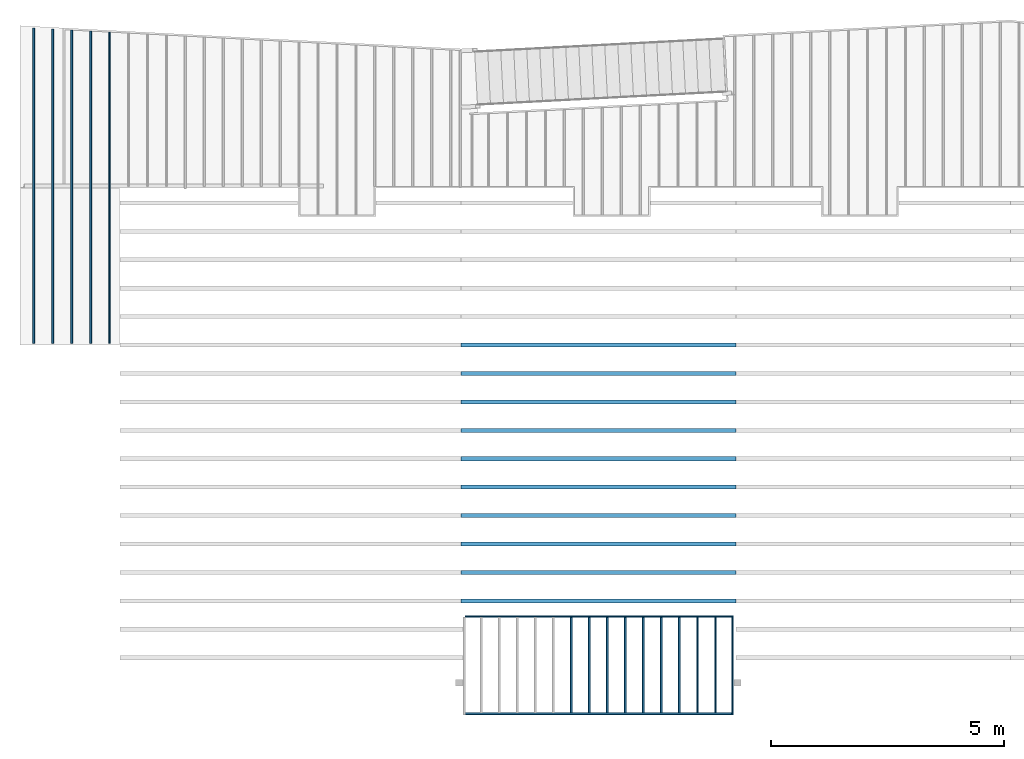
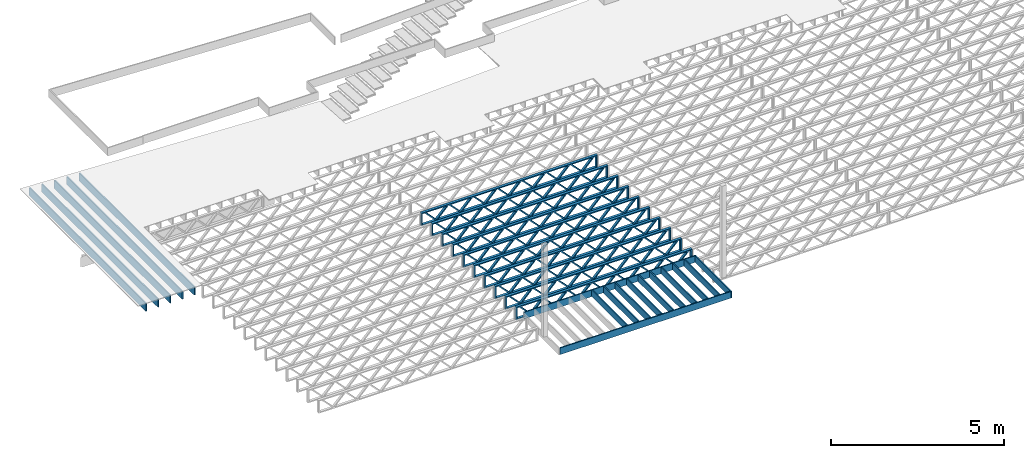
# One storey, part 2 of 23: 27 beams, 3 elements without a shape of their own.
"""IFC4 building model written with IfcOpenShell, lengths in feet."""

from ifc_helpers import new_model, entity, si_unit, converted_unit, derived_unit, direction, frame, frame_2d, origin, origin_2d_with_axis, place, context, subcontext, project, spatial, rectangle, extrude, source, transform, mapped, material, material_profile, profile_set, profile_usage, type_object, type_shapes, element, aggregate, save


model = new_model("IFC4")

# Units and contexts
model_context_1 = context("Model", 3, precision=0.0001, world=origin(), true_north=direction((6.12303176911189e-17, 1.0)))
model_context_2 = context("Model", 3, precision=0.0001, world=origin(), true_north=direction((6.12303176911189e-17, 1.0)))
body_context = subcontext(model_context_2, "Body", "Model", "MODEL_VIEW")
ifc_project = project(units=[converted_unit("LENGTHUNIT", "FOOT", entity("IfcRatioMeasure", 0.3048), si_unit("LENGTHUNIT", "METRE"), dimensions=[1, 0, 0, 0, 0, 0, 0]), converted_unit("AREAUNIT", "SQUARE FOOT", entity("IfcRatioMeasure", 0.09290304), si_unit("AREAUNIT", "SQUARE_METRE"), dimensions=[2, 0, 0, 0, 0, 0, 0]), converted_unit("VOLUMEUNIT", "CUBIC FOOT", entity("IfcRatioMeasure", 0.028316846592), si_unit("VOLUMEUNIT", "CUBIC_METRE"), dimensions=[3, 0, 0, 0, 0, 0, 0]), converted_unit("PLANEANGLEUNIT", "DEGREE", entity("IfcRatioMeasure", 0.0174532925199433), si_unit("PLANEANGLEUNIT", "RADIAN"), dimensions=[0, 0, 0, 0, 0, 0, 0]), si_unit("MASSUNIT", "GRAM", prefix="KILO"), derived_unit("MASSDENSITYUNIT", [(si_unit("MASSUNIT", "GRAM", prefix="KILO"), 1), (si_unit("LENGTHUNIT", "METRE"), -3)]), derived_unit("MOMENTOFINERTIAUNIT", [(si_unit("LENGTHUNIT", "METRE"), 4)]), si_unit("TIMEUNIT", "SECOND"), si_unit("FREQUENCYUNIT", "HERTZ"), si_unit("THERMODYNAMICTEMPERATUREUNIT", "DEGREE_CELSIUS"), derived_unit("THERMALTRANSMITTANCEUNIT", [(si_unit("MASSUNIT", "GRAM", prefix="KILO"), 1), (si_unit("THERMODYNAMICTEMPERATUREUNIT", "KELVIN"), -1), (si_unit("TIMEUNIT", "SECOND"), -3)]), derived_unit("VOLUMETRICFLOWRATEUNIT", [(si_unit("LENGTHUNIT", "METRE"), 3), (si_unit("TIMEUNIT", "SECOND"), -1)]), si_unit("ELECTRICCURRENTUNIT", "AMPERE"), si_unit("ELECTRICVOLTAGEUNIT", "VOLT"), si_unit("POWERUNIT", "WATT"), si_unit("FORCEUNIT", "NEWTON"), si_unit("ILLUMINANCEUNIT", "LUX"), si_unit("LUMINOUSFLUXUNIT", "LUMEN"), si_unit("LUMINOUSINTENSITYUNIT", "CANDELA"), derived_unit("USERDEFINED", [(si_unit("MASSUNIT", "GRAM", prefix="KILO"), -1), (si_unit("LENGTHUNIT", "METRE"), -2), (si_unit("TIMEUNIT", "SECOND"), 3), (si_unit("LUMINOUSFLUXUNIT", "LUMEN"), 1)]), derived_unit("LINEARVELOCITYUNIT", [(si_unit("LENGTHUNIT", "METRE"), 1), (si_unit("TIMEUNIT", "SECOND"), -1)]), si_unit("PRESSUREUNIT", "PASCAL"), derived_unit("USERDEFINED", [(si_unit("LENGTHUNIT", "METRE"), -2), (si_unit("MASSUNIT", "GRAM", prefix="KILO"), 1), (si_unit("TIMEUNIT", "SECOND"), -2)]), derived_unit("LINEARFORCEUNIT", [(si_unit("MASSUNIT", "GRAM", prefix="KILO"), 1), (si_unit("LENGTHUNIT", "METRE"), 1), (si_unit("TIMEUNIT", "SECOND"), -2), (si_unit("LENGTHUNIT", "METRE"), -1)]), derived_unit("PLANARFORCEUNIT", [(si_unit("MASSUNIT", "GRAM", prefix="KILO"), 1), (si_unit("LENGTHUNIT", "METRE"), 1), (si_unit("TIMEUNIT", "SECOND"), -2), (si_unit("LENGTHUNIT", "METRE"), -2)])], contexts=[model_context_1])

# Site, building, storey
site_placement = place(None, origin())
site = spatial("IfcSite", under=ifc_project, at=site_placement, CompositionType="ELEMENT")
building_placement = place(site_placement, origin())
building = spatial("IfcBuilding", under=site, at=building_placement, CompositionType="ELEMENT")
storey_placement = place(building_placement, frame((0.0, 0.0, 10.8020833333333)))
storey = spatial("IfcBuildingStorey", under=building, at=storey_placement, Name="2ND FLOOR", CompositionType="ELEMENT", Elevation=10.8020833333333)

# Assembly, beams
assembly_1_placement = place(storey_placement, origin())
assembly_1 = element("IfcElementAssembly", 1, at=assembly_1_placement, inside=storey, Name="Structural Beam System:Structural Framing System", ObjectType="Structural Beam System:Structural Framing System", AssemblyPlace="NOTDEFINED", PredefinedType="BEAM_GRID")
ifc_material_1 = material(Name="WOOD TRUSS", Category="Materials")
ifc_material_profile_1 = material_profile(ifc_material_1, rectangle(XDim=1.73473973950632, YDim=0.125, at=frame_2d((-1.11022302462516e-16, 8.32667268468867e-17), x_axis=(1.0, 0.0))))
ifc_material_profile_2 = material_profile(ifc_material_1, rectangle(XDim=1.73473973950633, YDim=0.125, at=frame_2d((-1.11022302462516e-16, 8.32667268468867e-17), x_axis=(1.0, 0.0))))
ifc_material_profile_3 = material_profile(ifc_material_1, rectangle(XDim=1.73473973950632, YDim=0.125, at=frame_2d((-5.55111512312578e-17, 1.38777878078145e-16), x_axis=(1.0, 0.0))))
ifc_material_profile_4 = material_profile(ifc_material_1, rectangle(XDim=1.73473973950633, YDim=0.125, at=frame_2d((-1.11022302462516e-16, 8.32667268468867e-17), x_axis=(1.0, 0.0))))
ifc_material_profile_5 = material_profile(ifc_material_1, rectangle(XDim=1.73473973950632, YDim=0.125, at=frame_2d((-1.11022302462516e-16, 8.32667268468867e-17), x_axis=(1.0, 0.0))))
ifc_material_profile_6 = material_profile(ifc_material_1, rectangle(XDim=1.73473973950633, YDim=0.125, at=frame_2d((-2.77555756156289e-16, 3.05311331771918e-16), x_axis=(1.0, 0.0))))
ifc_material_profile_7 = material_profile(ifc_material_1, rectangle(XDim=1.73473973950632, YDim=0.124999999999999, at=frame_2d((-3.88578058618805e-16, -2.4980018054066e-16), x_axis=(1.0, 0.0))))
ifc_material_profile_8 = material_profile(ifc_material_1, rectangle(XDim=1.73473973950633, YDim=0.125, at=frame_2d((2.77555756156289e-16, -3.05311331771918e-16), x_axis=(1.0, 0.0))))
ifc_material_profile_9 = material_profile(ifc_material_1, rectangle(XDim=1.73473973950632, YDim=0.124999999999999, at=frame_2d((-1.11022302462516e-16, 8.32667268468867e-17), x_axis=(1.0, 0.0))))
ifc_material_profile_10 = material_profile(ifc_material_1, rectangle(XDim=1.73473973950633, YDim=0.125, at=origin_2d_with_axis()))
ifc_material_profile_11 = material_profile(ifc_material_1, rectangle(XDim=0.124999999999982, YDim=0.291666666666668, at=origin_2d_with_axis()))
ifc_material_profile_12 = material_profile(ifc_material_1, rectangle(XDim=0.124999999999932, YDim=0.291666666666664, at=origin_2d_with_axis()))
ifc_material_profile_13 = material_profile(ifc_material_1, rectangle(XDim=1.25000000000002, YDim=0.29166666666667, at=origin_2d_with_axis()))
ifc_material_profile_14 = material_profile(ifc_material_1, rectangle(XDim=1.25000000000004, YDim=0.291666666666667, at=origin_2d_with_axis()))
ifc_profile_set_1 = profile_set([ifc_material_profile_1, ifc_material_profile_2, ifc_material_profile_3, ifc_material_profile_4, ifc_material_profile_5, ifc_material_profile_6, ifc_material_profile_7, ifc_material_profile_8, ifc_material_profile_9, ifc_material_profile_10, ifc_material_profile_11, ifc_material_profile_12, ifc_material_profile_13, ifc_material_profile_14])
ifc_profile_usage_1 = profile_usage(ifc_profile_set_1, cardinal=8)
beam_type_1 = type_object("IfcBeamType", PredefinedType="BEAM", material=ifc_profile_set_1)
shared_shape_1 = source(origin(), body_context, "Body", "SweptSolid", [
    extrude(rectangle(XDim=1.73473973950632, YDim=0.124999999999999, at=frame_2d((5.55111512312578e-16, 7.21644966006352e-16), x_axis=(1.0, 0.0))), frame((5.95847627016997, -0.145833333333334, 0.0), z_axis=(0.0, 1.0, 0.0), x_axis=(0.693383046997606, 0.0, 0.720569184836762)), (0.0, 0.0, 1.0), 0.291666666666667),
    extrude(rectangle(XDim=1.73473973950633, YDim=0.125, at=origin_2d_with_axis()), frame((4.7081903964967, -0.145833333333334, 0.0), z_axis=(0.0, 1.0, 0.0), x_axis=(0.69338304699761, 0.0, -0.720569184836758)), (0.0, 0.0, 1.0), 0.291666666666666),
    extrude(rectangle(XDim=1.73473973950632, YDim=0.125, at=frame_2d((2.22044604925031e-16, 3.88578058618805e-16), x_axis=(1.0, 0.0))), frame((3.29180960350347, -0.145833333333334, 0.0), z_axis=(0.0, 1.0, 0.0), x_axis=(0.693383046997606, 0.0, 0.720569184836762)), (0.0, 0.0, 1.0), 0.291666666666667),
    extrude(rectangle(XDim=1.73473973950633, YDim=0.125, at=frame_2d((1.11022302462516e-16, -8.32667268468867e-17), x_axis=(1.0, 0.0))), frame((2.0415237298302, -0.145833333333334, 0.0), z_axis=(0.0, 1.0, 0.0), x_axis=(0.69338304699761, 0.0, -0.720569184836758)), (0.0, 0.0, 1.0), 0.291666666666667),
    extrude(rectangle(XDim=1.73473973950632, YDim=0.125, at=frame_2d((-5.55111512312578e-17, 1.38777878078145e-16), x_axis=(1.0, 0.0))), frame((0.625142936836964, -0.145833333333334, 0.0), z_axis=(0.0, 1.0, 0.0), x_axis=(0.693383046997606, 0.0, 0.720569184836762)), (0.0, 0.0, 1.0), 0.291666666666667),
    extrude(rectangle(XDim=1.73473973950633, YDim=0.125, at=frame_2d((-1.11022302462516e-16, 8.32667268468867e-17), x_axis=(1.0, 0.0))), frame((-0.625142936836306, -0.145833333333334, 0.0), z_axis=(0.0, 1.0, 0.0), x_axis=(0.69338304699761, 0.0, -0.720569184836758)), (0.0, 0.0, 1.0), 0.291666666666667),
    extrude(rectangle(XDim=1.73473973950632, YDim=0.125, at=frame_2d((-1.11022302462516e-16, 8.32667268468867e-17), x_axis=(1.0, 0.0))), frame((-2.04152372982954, -0.145833333333334, 0.0), z_axis=(0.0, 1.0, 0.0), x_axis=(0.693383046997606, 0.0, 0.720569184836762)), (0.0, 0.0, 1.0), 0.291666666666667),
    extrude(rectangle(XDim=1.73473973950633, YDim=0.125, at=origin_2d_with_axis()), frame((-3.29180960350281, -0.145833333333334, 0.0), z_axis=(0.0, 1.0, 0.0), x_axis=(0.69338304699761, 0.0, -0.720569184836758)), (0.0, 0.0, 1.0), 0.291666666666667),
    extrude(rectangle(XDim=1.73473973950632, YDim=0.124999999999999, at=frame_2d((-1.11022302462516e-16, 8.32667268468867e-17), x_axis=(1.0, 0.0))), frame((-4.70819039649604, -0.145833333333334, 0.0), z_axis=(0.0, 1.0, 0.0), x_axis=(0.693383046997606, 0.0, 0.720569184836762)), (0.0, 0.0, 1.0), 0.291666666666667),
    extrude(rectangle(XDim=1.73473973950633, YDim=0.125, at=frame_2d((-5.55111512312578e-16, 6.38378239159465e-16), x_axis=(1.0, 0.0))), frame((-5.95847627016931, -0.145833333333334, 0.0), z_axis=(0.0, 1.0, 0.0), x_axis=(0.69338304699761, 0.0, -0.720569184836758)), (0.0, 0.0, 1.0), 0.291666666666666),
    extrude(rectangle(XDim=1.73473973950632, YDim=0.125, at=frame_2d((-7.21644966006352e-16, -5.82867087928207e-16), x_axis=(1.0, 0.0))), frame((8.62514293683647, -0.145833333333334, 0.0), z_axis=(0.0, 1.0, 0.0), x_axis=(0.693383046997607, 0.0, 0.720569184836761)), (0.0, 0.0, 1.0), 0.291666666666667),
    extrude(rectangle(XDim=1.73473973950633, YDim=0.125, at=origin_2d_with_axis()), frame((7.3748570631632, -0.145833333333334, 0.0), z_axis=(0.0, 1.0, 0.0), x_axis=(0.69338304699761, 0.0, -0.720569184836758)), (0.0, 0.0, 1.0), 0.291666666666666),
    extrude(rectangle(XDim=1.73473973950632, YDim=0.124999999999999, at=frame_2d((-1.11022302462516e-16, 8.32667268468867e-17), x_axis=(1.0, 0.0))), frame((-7.37485706316255, -0.145833333333334, 0.0), z_axis=(0.0, 1.0, 0.0), x_axis=(0.693383046997606, 0.0, 0.720569184836762)), (0.0, 0.0, 1.0), 0.291666666666667),
    extrude(rectangle(XDim=1.73473973950633, YDim=0.125, at=origin_2d_with_axis()), frame((-8.62514293683582, -0.145833333333334, 0.0), z_axis=(0.0, 1.0, 0.0), x_axis=(0.69338304699761, 0.0, -0.720569184836758)), (0.0, 0.0, 1.0), 0.291666666666666),
    extrude(rectangle(XDim=0.124999999999982, YDim=0.291666666666668, at=origin_2d_with_axis()), frame((-9.66666666666609, 0.0, 0.687500000000054), z_axis=(1.0, 0.0, 0.0), x_axis=(0.0, 0.0, -1.0)), (0.0, 0.0, 1.0), 19.3333333333322),
    extrude(rectangle(XDim=0.124999999999932, YDim=0.291666666666664, at=origin_2d_with_axis()), frame((-9.66666666666588, 0.0, -0.687499999999984), z_axis=(1.0, 0.0, 0.0), x_axis=(0.0, 0.0, -1.0)), (0.0, 0.0, 1.0), 19.333333333332),
    extrude(rectangle(XDim=1.25000000000002, YDim=0.29166666666667, at=origin_2d_with_axis()), frame((9.54166666666607, 0.0, 0.0), z_axis=(1.0, 0.0, 0.0), x_axis=(0.0, 0.0, -1.0)), (0.0, 0.0, 1.0), 0.12500000000002),
    extrude(rectangle(XDim=1.25000000000004, YDim=0.291666666666667, at=origin_2d_with_axis()), frame((-9.66666666666609, 0.0, 0.0), z_axis=(1.0, 0.0, 0.0), x_axis=(0.0, 0.0, -1.0)), (0.0, 0.0, 1.0), 0.125000000000023),
])
type_shapes(beam_type_1, [shared_shape_1])
beam_1_placement = place(assembly_1_placement, frame((-232.071493788723, 947.861934882651, -0.947916666666657)))
beam_1 = element("IfcBeam", 2, at=beam_1_placement, type_object=beam_type_1, material=ifc_profile_usage_1, PredefinedType="BEAM", context=body_context, shape_type="MappedRepresentation", body=[
    mapped(shared_shape_1, transform((0.0, 0.0, 0.0), scale=1.0)),
])
ifc_profile_usage_2 = profile_usage(ifc_profile_set_1, cardinal=8)
beam_2_placement = place(assembly_1_placement, frame((-232.071493788723, 945.861934882651, -0.947916666666657)))
beam_2 = element("IfcBeam", 3, at=beam_2_placement, type_object=beam_type_1, material=ifc_profile_usage_2, PredefinedType="BEAM", context=body_context, shape_type="MappedRepresentation", body=[
    mapped(shared_shape_1, transform((0.0, 0.0, 0.0), scale=1.0)),
])
ifc_profile_usage_3 = profile_usage(ifc_profile_set_1, cardinal=8)
beam_3_placement = place(assembly_1_placement, frame((-232.071493788723, 943.861934882651, -0.947916666666657)))
beam_3 = element("IfcBeam", 4, at=beam_3_placement, type_object=beam_type_1, material=ifc_profile_usage_3, PredefinedType="BEAM", context=body_context, shape_type="MappedRepresentation", body=[
    mapped(shared_shape_1, transform((0.0, 0.0, 0.0), scale=1.0)),
])
ifc_profile_usage_4 = profile_usage(ifc_profile_set_1, cardinal=8)
beam_4_placement = place(assembly_1_placement, frame((-232.071493788723, 941.861934882651, -0.947916666666657)))
beam_4 = element("IfcBeam", 5, at=beam_4_placement, type_object=beam_type_1, material=ifc_profile_usage_4, PredefinedType="BEAM", context=body_context, shape_type="MappedRepresentation", body=[
    mapped(shared_shape_1, transform((0.0, 0.0, 0.0), scale=1.0)),
])
ifc_profile_usage_5 = profile_usage(ifc_profile_set_1, cardinal=8)
beam_5_placement = place(assembly_1_placement, frame((-232.071493788723, 939.861934882651, -0.947916666666657)))
beam_5 = element("IfcBeam", 6, at=beam_5_placement, type_object=beam_type_1, material=ifc_profile_usage_5, PredefinedType="BEAM", context=body_context, shape_type="MappedRepresentation", body=[
    mapped(shared_shape_1, transform((0.0, 0.0, 0.0), scale=1.0)),
])
ifc_profile_usage_6 = profile_usage(ifc_profile_set_1, cardinal=8)
beam_6_placement = place(assembly_1_placement, frame((-232.071493788723, 937.861934882651, -0.947916666666657)))
beam_6 = element("IfcBeam", 7, at=beam_6_placement, type_object=beam_type_1, material=ifc_profile_usage_6, PredefinedType="BEAM", context=body_context, shape_type="MappedRepresentation", body=[
    mapped(shared_shape_1, transform((0.0, 0.0, 0.0), scale=1.0)),
])
ifc_profile_usage_7 = profile_usage(ifc_profile_set_1, cardinal=8)
beam_7_placement = place(assembly_1_placement, frame((-232.071493788723, 935.861934882651, -0.947916666666657)))
beam_7 = element("IfcBeam", 8, at=beam_7_placement, type_object=beam_type_1, material=ifc_profile_usage_7, PredefinedType="BEAM", context=body_context, shape_type="MappedRepresentation", body=[
    mapped(shared_shape_1, transform((0.0, 0.0, 0.0), scale=1.0)),
])
ifc_profile_usage_8 = profile_usage(ifc_profile_set_1, cardinal=8)
beam_8_placement = place(assembly_1_placement, frame((-232.071493788723, 933.861934882651, -0.947916666666657)))
beam_8 = element("IfcBeam", 9, at=beam_8_placement, type_object=beam_type_1, material=ifc_profile_usage_8, PredefinedType="BEAM", context=body_context, shape_type="MappedRepresentation", body=[
    mapped(shared_shape_1, transform((0.0, 0.0, 0.0), scale=1.0)),
])
ifc_profile_usage_9 = profile_usage(ifc_profile_set_1, cardinal=8)
beam_9_placement = place(assembly_1_placement, frame((-232.071493788723, 931.861934882651, -0.947916666666657)))
beam_9 = element("IfcBeam", 10, at=beam_9_placement, type_object=beam_type_1, material=ifc_profile_usage_9, PredefinedType="BEAM", context=body_context, shape_type="MappedRepresentation", body=[
    mapped(shared_shape_1, transform((0.0, 0.0, 0.0), scale=1.0)),
])
ifc_profile_usage_10 = profile_usage(ifc_profile_set_1, cardinal=8)
beam_10_placement = place(assembly_1_placement, frame((-232.071493788723, 929.861934882651, -0.947916666666657)))
beam_10 = element("IfcBeam", 11, at=beam_10_placement, type_object=beam_type_1, material=ifc_profile_usage_10, PredefinedType="BEAM", context=body_context, shape_type="MappedRepresentation", body=[
    mapped(shared_shape_1, transform((0.0, 0.0, 0.0), scale=1.0)),
])
aggregate(assembly_1, [beam_1, beam_2, beam_3, beam_4, beam_5, beam_6, beam_7, beam_8, beam_9, beam_10])

assembly_2_placement = place(storey_placement, origin())
assembly_2 = element("IfcElementAssembly", 12, at=assembly_2_placement, inside=storey, Name="Structural Beam System:Structural Framing System", ObjectType="Structural Beam System:Structural Framing System", AssemblyPlace="NOTDEFINED", PredefinedType="BEAM_GRID")
ifc_material_2 = material(Category="Materials")
ifc_material_profile_15 = material_profile(ifc_material_2, rectangle(XDim=0.770833333333333, YDim=0.124999999999994, at=frame_2d((-5.55111512312578e-17, 0.0), x_axis=(1.0, 0.0))))
ifc_profile_set_2 = profile_set([ifc_material_profile_15])
ifc_profile_usage_11 = profile_usage(ifc_profile_set_2, cardinal=8)
beam_type_2 = type_object("IfcBeamType", PredefinedType="BEAM", material=ifc_profile_set_2)
shared_shape_2 = source(origin(), body_context, "Body", "SweptSolid", [
    extrude(rectangle(XDim=0.770833333333333, YDim=0.124999999999994, at=frame_2d((-5.55111512312578e-17, 0.0), x_axis=(1.0, 0.0))), frame((-3.35416666666737, 0.0, 0.0), z_axis=(1.0, 0.0, 0.0), x_axis=(0.0, 0.0, -1.0)), (0.0, 0.0, 1.0), 6.70833333333462),
])
type_shapes(beam_type_2, [shared_shape_2])
beam_11_placement = place(assembly_2_placement, frame((-233.973446212303, 925.341101549317, -0.645833333333471), z_axis=(0.0, 0.0, 1.0), x_axis=(0.0, 1.0, 0.0)))
beam_11 = element("IfcBeam", 13, at=beam_11_placement, type_object=beam_type_2, material=ifc_profile_usage_11, PredefinedType="BEAM", context=body_context, shape_type="MappedRepresentation", body=[
    mapped(shared_shape_2, transform((0.0, 0.0, 0.0), scale=1.0)),
])
ifc_profile_usage_12 = profile_usage(ifc_profile_set_2, cardinal=8)
beam_12_placement = place(assembly_2_placement, frame((-232.706562531745, 925.341101549317, -0.645833333333471), z_axis=(0.0, 0.0, 1.0), x_axis=(0.0, 1.0, 0.0)))
beam_12 = element("IfcBeam", 14, at=beam_12_placement, type_object=beam_type_2, material=ifc_profile_usage_12, PredefinedType="BEAM", context=body_context, shape_type="MappedRepresentation", body=[
    mapped(shared_shape_2, transform((0.0, 0.0, 0.0), scale=1.0)),
])
ifc_profile_usage_13 = profile_usage(ifc_profile_set_2, cardinal=8)
beam_13_placement = place(assembly_2_placement, frame((-231.439678851187, 925.341101549318, -0.645833333333433), z_axis=(0.0, 0.0, 1.0), x_axis=(0.0, 1.0, 0.0)))
beam_13 = element("IfcBeam", 15, at=beam_13_placement, type_object=beam_type_2, material=ifc_profile_usage_13, PredefinedType="BEAM", context=body_context, shape_type="MappedRepresentation", body=[
    mapped(shared_shape_2, transform((0.0, 0.0, 0.0), scale=1.0)),
])
ifc_profile_usage_14 = profile_usage(ifc_profile_set_2, cardinal=8)
beam_14_placement = place(assembly_2_placement, frame((-230.172795170628, 925.341101549318, -0.645833333333471), z_axis=(0.0, 0.0, 1.0), x_axis=(0.0, 1.0, 0.0)))
beam_14 = element("IfcBeam", 16, at=beam_14_placement, type_object=beam_type_2, material=ifc_profile_usage_14, PredefinedType="BEAM", context=body_context, shape_type="MappedRepresentation", body=[
    mapped(shared_shape_2, transform((0.0, 0.0, 0.0), scale=1.0)),
])
ifc_profile_usage_15 = profile_usage(ifc_profile_set_2, cardinal=8)
beam_15_placement = place(assembly_2_placement, frame((-228.90591149007, 925.341101549318, -0.645833333333471), z_axis=(0.0, 0.0, 1.0), x_axis=(0.0, 1.0, 0.0)))
beam_15 = element("IfcBeam", 17, at=beam_15_placement, type_object=beam_type_2, material=ifc_profile_usage_15, PredefinedType="BEAM", context=body_context, shape_type="MappedRepresentation", body=[
    mapped(shared_shape_2, transform((0.0, 0.0, 0.0), scale=1.0)),
])
ifc_profile_usage_16 = profile_usage(ifc_profile_set_2, cardinal=8)
beam_16_placement = place(assembly_2_placement, frame((-227.639027809511, 925.341101549318, -0.645833333333471), z_axis=(0.0, 0.0, 1.0), x_axis=(0.0, 1.0, 0.0)))
beam_16 = element("IfcBeam", 18, at=beam_16_placement, type_object=beam_type_2, material=ifc_profile_usage_16, PredefinedType="BEAM", context=body_context, shape_type="MappedRepresentation", body=[
    mapped(shared_shape_2, transform((0.0, 0.0, 0.0), scale=1.0)),
])
ifc_profile_usage_17 = profile_usage(ifc_profile_set_2, cardinal=8)
beam_17_placement = place(assembly_2_placement, frame((-226.372144128953, 925.341101549318, -0.645833333333471), z_axis=(0.0, 0.0, 1.0), x_axis=(0.0, 1.0, 0.0)))
beam_17 = element("IfcBeam", 19, at=beam_17_placement, type_object=beam_type_2, material=ifc_profile_usage_17, PredefinedType="BEAM", context=body_context, shape_type="MappedRepresentation", body=[
    mapped(shared_shape_2, transform((0.0, 0.0, 0.0), scale=1.0)),
])
ifc_profile_usage_18 = profile_usage(ifc_profile_set_2, cardinal=8)
beam_18_placement = place(assembly_2_placement, frame((-225.105260448395, 925.341101549318, -0.645833333333471), z_axis=(0.0, 0.0, 1.0), x_axis=(0.0, 1.0, 0.0)))
beam_18 = element("IfcBeam", 20, at=beam_18_placement, type_object=beam_type_2, material=ifc_profile_usage_18, PredefinedType="BEAM", context=body_context, shape_type="MappedRepresentation", body=[
    mapped(shared_shape_2, transform((0.0, 0.0, 0.0), scale=1.0)),
])
ifc_profile_usage_19 = profile_usage(ifc_profile_set_2, cardinal=8)
beam_19_placement = place(assembly_2_placement, frame((-223.838376767836, 925.341101549319, -0.645833333333471), z_axis=(0.0, 0.0, 1.0), x_axis=(0.0, 1.0, 0.0)))
beam_19 = element("IfcBeam", 21, at=beam_19_placement, type_object=beam_type_2, material=ifc_profile_usage_19, PredefinedType="BEAM", context=body_context, shape_type="MappedRepresentation", body=[
    mapped(shared_shape_2, transform((0.0, 0.0, 0.0), scale=1.0)),
])
aggregate(assembly_2, [beam_11, beam_12, beam_13, beam_14, beam_15, beam_16, beam_17, beam_18, beam_19])

# Beams
ifc_profile_usage_20 = profile_usage(ifc_profile_set_2, cardinal=8)
beam_type_3 = type_object("IfcBeamType", PredefinedType="BEAM", material=ifc_profile_set_2)
shared_shape_3 = source(origin(), body_context, "Body", "SweptSolid", [
    extrude(rectangle(XDim=0.770833333333333, YDim=0.124999999999994, at=origin_2d_with_axis()), frame((-9.49999887751909, 0.0, 0.0), z_axis=(1.0, 0.0, 0.0), x_axis=(0.0, 0.0, -1.0)), (0.0, 0.0, 1.0), 18.8749977550383),
])
type_shapes(beam_type_3, [shared_shape_3])
beam_20_placement = place(storey_placement, frame((-232.071494941343, 928.757768215985, -0.645833333333506), z_axis=(0.0, 0.0, 1.0), x_axis=(-1.0, 0.0, 0.0)))
element("IfcBeam", 22, at=beam_20_placement, inside=storey, type_object=beam_type_3, material=ifc_profile_usage_20, PredefinedType="BEAM", context=body_context, shape_type="MappedRepresentation", body=[
    mapped(shared_shape_3, transform((0.0, 0.0, 0.0), scale=1.0)),
])
ifc_profile_usage_21 = profile_usage(ifc_profile_set_2, cardinal=8)
beam_type_4 = type_object("IfcBeamType", PredefinedType="BEAM", material=ifc_profile_set_2)
shared_shape_4 = source(origin(), body_context, "Body", "SweptSolid", [
    extrude(rectangle(XDim=0.770833333333333, YDim=0.124999999999994, at=origin_2d_with_axis()), frame((-3.47916666666737, 0.0, 0.0), z_axis=(1.0, 0.0, 0.0), x_axis=(0.0, 0.0, -1.0)), (0.0, 0.0, 1.0), 6.83333333333471),
])
type_shapes(beam_type_4, [shared_shape_4])
beam_21_placement = place(storey_placement, frame((-222.633996063824, 925.341101549319, -0.645833333333512), z_axis=(0.0, 0.0, 1.0), x_axis=(0.0, 1.0, 0.0)))
element("IfcBeam", 23, at=beam_21_placement, inside=storey, type_object=beam_type_4, material=ifc_profile_usage_21, PredefinedType="BEAM", context=body_context, shape_type="MappedRepresentation", body=[
    mapped(shared_shape_4, transform((0.0, 0.0, 0.0), scale=1.0)),
])
ifc_material_3 = material(Name="BRAKE METAL FLASHING AT PERIMETER 2X LEDGER", Category="Materials")
ifc_material_profile_16 = material_profile(ifc_material_3, rectangle(XDim=0.770833333333333, YDim=0.124999999999994, at=frame_2d((-1.11022302462516e-16, 0.0), x_axis=(1.0, 0.0))), Name="BRAKE METAL FLASHING AT PERIMETER 2X LEDGER")
ifc_profile_set_3 = profile_set([ifc_material_profile_16], Name="BRAKE METAL FLASHING AT PERIMETER 2X LEDGER")
ifc_profile_usage_22 = profile_usage(ifc_profile_set_3, cardinal=8)
beam_type_5 = type_object("IfcBeamType", PredefinedType="BEAM", material=ifc_profile_set_3)
shared_shape_5 = source(origin(), body_context, "Body", "SweptSolid", [
    extrude(rectangle(XDim=0.770833333333333, YDim=0.124999999999994, at=origin_2d_with_axis()), frame((-9.37499887751909, 0.0, 0.0), z_axis=(1.0, 0.0, 0.0), x_axis=(0.0, 0.0, -1.0)), (0.0, 0.0, 1.0), 18.7499977550382),
])
type_shapes(beam_type_5, [shared_shape_5])
beam_22_placement = place(storey_placement, frame((-232.071494941343, 921.92443488265, -0.645833333333494), z_axis=(0.0, 0.0, 1.0), x_axis=(-1.0, 0.0, 0.0)))
element("IfcBeam", 24, at=beam_22_placement, inside=storey, type_object=beam_type_5, material=ifc_profile_usage_22, PredefinedType="BEAM", context=body_context, shape_type="MappedRepresentation", body=[
    mapped(shared_shape_5, transform((0.0, 0.0, 0.0), scale=1.0)),
])

# Assembly, beams
assembly_3_placement = place(storey_placement, origin())
assembly_3 = element("IfcElementAssembly", 25, at=assembly_3_placement, inside=storey, Name="Structural Beam System:Structural Framing System", ObjectType="Structural Beam System:Structural Framing System", AssemblyPlace="NOTDEFINED", PredefinedType="BEAM_GRID")
ifc_material_profile_17 = material_profile(ifc_material_2, rectangle(XDim=0.9375, YDim=0.125000000000011, at=origin_2d_with_axis()))
ifc_profile_set_4 = profile_set([ifc_material_profile_17])
ifc_profile_usage_23 = profile_usage(ifc_profile_set_4, cardinal=8)
beam_type_6 = type_object("IfcBeamType", PredefinedType="BEAM", material=ifc_profile_set_4)
shared_shape_6 = source(origin(), body_context, "Body", "SweptSolid", [
    extrude(rectangle(XDim=0.9375, YDim=0.125000000000011, at=origin_2d_with_axis()), frame((-10.946155976231, 0.0, 0.0), z_axis=(1.0, 0.0, 0.0), x_axis=(0.0, 0.0, -1.0)), (0.0, 0.0, 1.0), 21.8923119524619),
])
type_shapes(beam_type_6, [shared_shape_6])
beam_23_placement = place(assembly_3_placement, frame((-266.467327152129, 958.933090858882, -0.729166666666744), z_axis=(0.0, 0.0, 1.0), x_axis=(0.0, 1.0, 0.0)))
beam_23 = element("IfcBeam", 26, at=beam_23_placement, type_object=beam_type_6, material=ifc_profile_usage_23, PredefinedType="BEAM", context=body_context, shape_type="MappedRepresentation", body=[
    mapped(shared_shape_6, transform((0.0, 0.0, 0.0), scale=1.0)),
])
ifc_profile_usage_24 = profile_usage(ifc_profile_set_4, cardinal=8)
beam_type_7 = type_object("IfcBeamType", PredefinedType="BEAM", material=ifc_profile_set_4)
shared_shape_7 = source(origin(), body_context, "Body", "SweptSolid", [
    extrude(rectangle(XDim=0.9375, YDim=0.125000000000011, at=origin_2d_with_axis()), frame((-11.016033015275, 0.0, 0.0), z_axis=(1.0, 0.0, 0.0), x_axis=(0.0, 0.0, -1.0)), (0.0, 0.0, 1.0), 22.03206603055),
])
type_shapes(beam_type_7, [shared_shape_7])
beam_24_placement = place(assembly_3_placement, frame((-269.133993818795, 959.002967897926, -0.729166666666744), z_axis=(0.0, 0.0, 1.0), x_axis=(0.0, 1.0, 0.0)))
beam_24 = element("IfcBeam", 27, at=beam_24_placement, type_object=beam_type_7, material=ifc_profile_usage_24, PredefinedType="BEAM", context=body_context, shape_type="MappedRepresentation", body=[
    mapped(shared_shape_7, transform((0.0, 0.0, 0.0), scale=1.0)),
])
ifc_profile_usage_25 = profile_usage(ifc_profile_set_4, cardinal=8)
beam_type_8 = type_object("IfcBeamType", PredefinedType="BEAM", material=ifc_profile_set_4)
shared_shape_8 = source(origin(), body_context, "Body", "SweptSolid", [
    extrude(rectangle(XDim=0.9375, YDim=0.125000000000011, at=origin_2d_with_axis()), frame((-11.050971534797, 0.0, 0.0), z_axis=(1.0, 0.0, 0.0), x_axis=(0.0, 0.0, -1.0)), (0.0, 0.0, 1.0), 22.1019430695941),
])
type_shapes(beam_type_8, [shared_shape_8])
beam_25_placement = place(assembly_3_placement, frame((-270.467327152129, 959.037906417448, -0.729166666666744), z_axis=(0.0, 0.0, 1.0), x_axis=(0.0, 1.0, 0.0)))
beam_25 = element("IfcBeam", 28, at=beam_25_placement, type_object=beam_type_8, material=ifc_profile_usage_25, PredefinedType="BEAM", context=body_context, shape_type="MappedRepresentation", body=[
    mapped(shared_shape_8, transform((0.0, 0.0, 0.0), scale=1.0)),
])
ifc_profile_usage_26 = profile_usage(ifc_profile_set_4, cardinal=8)
beam_type_9 = type_object("IfcBeamType", PredefinedType="BEAM", material=ifc_profile_set_4)
shared_shape_9 = source(origin(), body_context, "Body", "SweptSolid", [
    extrude(rectangle(XDim=0.9375, YDim=0.125000000000011, at=origin_2d_with_axis()), frame((-11.0859100543191, 0.0, 0.0), z_axis=(1.0, 0.0, 0.0), x_axis=(0.0, 0.0, -1.0)), (0.0, 0.0, 1.0), 22.1718201086381),
])
type_shapes(beam_type_9, [shared_shape_9])
beam_26_placement = place(assembly_3_placement, frame((-271.800660485462, 959.07284493697, -0.729166666666744), z_axis=(0.0, 0.0, 1.0), x_axis=(0.0, 1.0, 0.0)))
beam_26 = element("IfcBeam", 29, at=beam_26_placement, type_object=beam_type_9, material=ifc_profile_usage_26, PredefinedType="BEAM", context=body_context, shape_type="MappedRepresentation", body=[
    mapped(shared_shape_9, transform((0.0, 0.0, 0.0), scale=1.0)),
])
ifc_profile_usage_27 = profile_usage(ifc_profile_set_4, cardinal=8)
beam_type_10 = type_object("IfcBeamType", PredefinedType="BEAM", material=ifc_profile_set_4)
shared_shape_10 = source(origin(), body_context, "Body", "SweptSolid", [
    extrude(rectangle(XDim=0.9375, YDim=0.125000000000011, at=origin_2d_with_axis()), frame((-10.981094495753, 0.0, 0.0), z_axis=(1.0, 0.0, 0.0), x_axis=(0.0, 0.0, -1.0)), (0.0, 0.0, 1.0), 21.962188991506),
])
type_shapes(beam_type_10, [shared_shape_10])
beam_27_placement = place(assembly_3_placement, frame((-267.800660485462, 958.968029378404, -0.729166666666744), z_axis=(0.0, 0.0, 1.0), x_axis=(0.0, 1.0, 0.0)))
beam_27 = element("IfcBeam", 30, at=beam_27_placement, type_object=beam_type_10, material=ifc_profile_usage_27, PredefinedType="BEAM", context=body_context, shape_type="MappedRepresentation", body=[
    mapped(shared_shape_10, transform((0.0, 0.0, 0.0), scale=1.0)),
])
aggregate(assembly_3, [beam_23, beam_24, beam_25, beam_26, beam_27])

save(model, "model.ifc")
